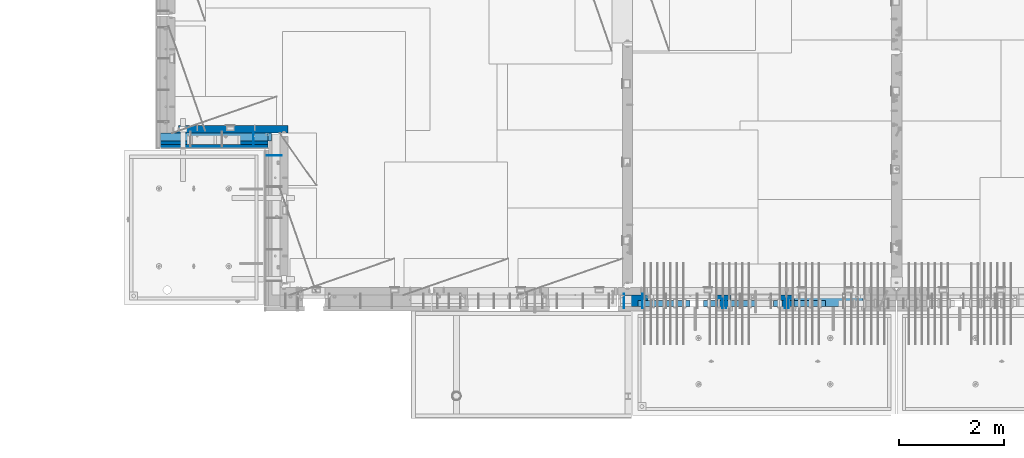
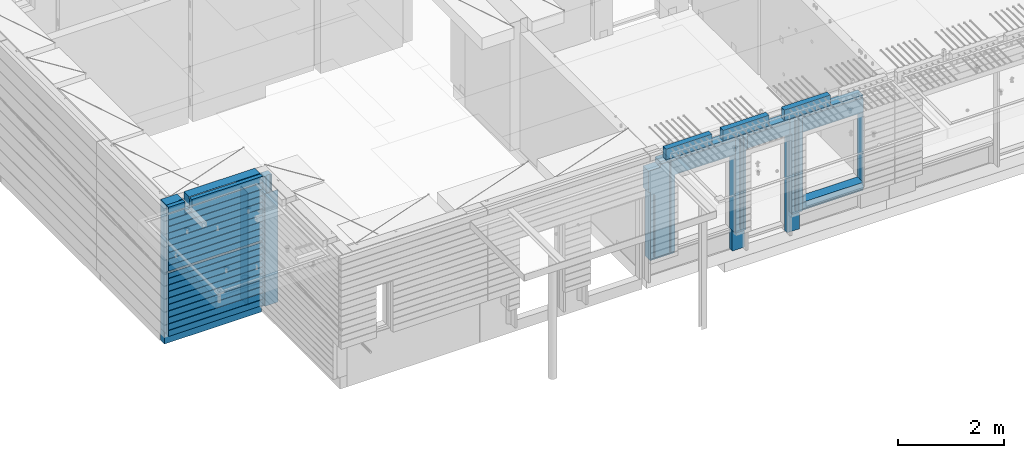
# One storey, part 209 of 325: 20 walls, 7 elements without a shape of their own.
"""IFC2X3 building model written with IfcOpenShell, lengths in millimetres."""

from ifc_helpers import new_model, si_unit, frame, origin_with_axes, place, context, subcontext, project, spatial, faceted_brep, material, type_object, element, aggregate, save


model = new_model("IFC2X3")

# Units and contexts
model_context = context("Model", 3, precision=1e-05, world=origin_with_axes())
body_context = subcontext(model_context, "Body", "Model", "MODEL_VIEW")
ifc_project = project(units=[si_unit("LENGTHUNIT", "METRE", prefix="MILLI"), si_unit("AREAUNIT", "SQUARE_METRE"), si_unit("VOLUMEUNIT", "CUBIC_METRE"), si_unit("MASSUNIT", "GRAM", prefix="KILO"), si_unit("TIMEUNIT", "SECOND"), si_unit("PLANEANGLEUNIT", "RADIAN"), si_unit("SOLIDANGLEUNIT", "STERADIAN"), si_unit("THERMODYNAMICTEMPERATUREUNIT", "DEGREE_CELSIUS"), si_unit("LUMINOUSINTENSITYUNIT", "LUMEN")], contexts=[model_context])

# Site, building, storey
site_placement = place(None, origin_with_axes())
site = spatial("IfcSite", under=ifc_project, at=site_placement, CompositionType="ELEMENT")
building_placement = place(site_placement, origin_with_axes())
building = spatial("IfcBuilding", under=site, at=building_placement, CompositionType="ELEMENT")
storey_placement = place(building_placement, origin_with_axes())
storey = spatial("IfcBuildingStorey", under=building, at=storey_placement, Name="1", CompositionType="ELEMENT", Elevation=0.0)

# Assembly, wall
assembly_1_placement = place(storey_placement, origin_with_axes())
assembly_1 = element("IfcElementAssembly", 1, at=assembly_1_placement, inside=storey, AssemblyPlace="NOTDEFINED", PredefinedType="REINFORCEMENT_UNIT")
ifc_material_1 = material(Name="Undefined")
wall_type_1 = type_object("IfcWallType", PredefinedType="NOTDEFINED")
wall_1_placement = place(assembly_1_placement, frame((10040.0, 10525.0, 83115.0), z_axis=(0.0, 0.0, 1.0), x_axis=(-1.0, 3.00000001838171e-08, 0.0)))
wall_1 = element("IfcWall", 2, at=wall_1_placement, type_object=wall_type_1, material=ifc_material_1, Name="(PD)", context=body_context, shape_type="Brep", body=[
    faceted_brep([(0.0, 5.0, -1300.0), (0.0, 5.0, 1300.0), (280.0, 5.0, 1300.0), (280.0, 5.0, -1300.0), (0.0, -5.0, 1300.0), (280.0, -5.0, 1300.0), (0.0, -5.0, -1300.0), (280.0, -5.0, -1300.0)], [[[0, 1, 2, 3]], [[1, 4, 5, 2]], [[4, 6, 7, 5]], [[6, 0, 3, 7]], [[5, 7, 3, 2]], [[6, 4, 1, 0]]]),
])
aggregate(assembly_1, [wall_1])

assembly_2_placement = place(storey_placement, origin_with_axes())
assembly_2 = element("IfcElementAssembly", 3, at=assembly_2_placement, inside=storey, AssemblyPlace="NOTDEFINED", PredefinedType="REINFORCEMENT_UNIT")
wall_2_placement = place(assembly_2_placement, frame((9500.0, 10980.0, 83115.0), z_axis=(0.0, 0.0, 1.0), x_axis=(0.0, -1.0, 0.0)))
wall_2 = element("IfcWall", 4, at=wall_2_placement, type_object=wall_type_1, material=ifc_material_1, Name="(PD)", context=body_context, shape_type="Brep", body=[
    faceted_brep([(0.0, 5.0, -1300.0), (0.0, 5.0, 1300.0), (280.0, 5.0, 1300.0), (280.0, 5.0, -1300.0), (0.0, -5.0, 1300.0), (280.0, -5.0, 1300.0), (0.0, -5.0, -1300.0), (280.0, -5.0, -1300.0)], [[[0, 1, 2, 3]], [[1, 4, 5, 2]], [[4, 6, 7, 5]], [[6, 0, 3, 7]], [[5, 7, 3, 2]], [[6, 4, 1, 0]]]),
])

# Assemblies, walls
assembly_3_placement = place(storey_placement, origin_with_axes())
assembly_3 = element("IfcElementAssembly", 5, at=assembly_3_placement, inside=storey, AssemblyPlace="NOTDEFINED", PredefinedType="REINFORCEMENT_UNIT")
assembly_4_placement = place(assembly_3_placement, origin_with_axes())
assembly_4 = element("IfcElementAssembly", 6, at=assembly_4_placement, Name="Steel Assembly", AssemblyPlace="NOTDEFINED", PredefinedType="NOTDEFINED")
ifc_material_2 = material()
wall_type_2 = type_object("IfcWallType", PredefinedType="NOTDEFINED")
wall_3_placement = place(assembly_4_placement, frame((16859.9998568133, 7690.00021946163, 84590.0), z_axis=(0.0, 0.0, 1.0), x_axis=(1.0, 0.0, 0.0)))
wall_3 = element("IfcWall", 7, at=wall_3_placement, type_object=wall_type_2, material=ifc_material_2, context=body_context, shape_type="Brep", body=[
    faceted_brep([(0.0, 60.0, -120.0), (0.0, 60.0, 120.0), (1000.0, 60.0, 120.0), (1000.0, 60.0, -120.0), (0.0, -60.0, 120.0), (1000.0, -60.0, 120.0), (0.0, -60.0, -120.0), (1000.0, -60.0, -120.0)], [[[0, 1, 2, 3]], [[1, 4, 5, 2]], [[4, 6, 7, 5]], [[6, 0, 3, 7]], [[5, 7, 3, 2]], [[6, 4, 1, 0]]]),
])
aggregate(assembly_4, [wall_3])
assembly_5_placement = place(assembly_3_placement, origin_with_axes())
assembly_5 = element("IfcElementAssembly", 8, at=assembly_5_placement, Name="Steel Assembly", AssemblyPlace="NOTDEFINED", PredefinedType="NOTDEFINED")
wall_4_placement = place(assembly_5_placement, frame((18109.9998568133, 7690.00021946163, 84590.0), z_axis=(0.0, 0.0, 1.0), x_axis=(1.0, 0.0, 0.0)))
wall_4 = element("IfcWall", 9, at=wall_4_placement, type_object=wall_type_2, material=ifc_material_2, context=body_context, shape_type="Brep", body=[
    faceted_brep([(0.0, 60.0, -120.0), (0.0, 60.0, 120.0), (1000.0, 60.0, 120.0), (1000.0, 60.0, -120.0), (0.0, -60.0, 120.0), (1000.0, -60.0, 120.0), (0.0, -60.0, -120.0), (1000.0, -60.0, -120.0)], [[[0, 1, 2, 3]], [[1, 4, 5, 2]], [[4, 6, 7, 5]], [[6, 0, 3, 7]], [[5, 7, 3, 2]], [[6, 4, 1, 0]]]),
])
aggregate(assembly_5, [wall_4])
assembly_6_placement = place(assembly_3_placement, origin_with_axes())
assembly_6 = element("IfcElementAssembly", 10, at=assembly_6_placement, Name="Steel Assembly", AssemblyPlace="NOTDEFINED", PredefinedType="NOTDEFINED")
aggregate(assembly_3, [assembly_6, assembly_5, assembly_4])
wall_5_placement = place(assembly_6_placement, frame((19449.9998568133, 7690.00021946163, 84590.0), z_axis=(0.0, 0.0, 1.0), x_axis=(1.0, 0.0, 0.0)))
wall_5 = element("IfcWall", 11, at=wall_5_placement, type_object=wall_type_2, material=ifc_material_2, context=body_context, shape_type="Brep", body=[
    faceted_brep([(0.0, 60.0, -120.0), (0.0, 60.0, 120.0), (1000.0, 60.0, 120.0), (1000.0, 60.0, -120.0), (0.0, -60.0, 120.0), (1000.0, -60.0, 120.0), (0.0, -60.0, -120.0), (1000.0, -60.0, -120.0)], [[[0, 1, 2, 3]], [[1, 4, 5, 2]], [[4, 6, 7, 5]], [[6, 0, 3, 7]], [[5, 7, 3, 2]], [[6, 4, 1, 0]]]),
])
aggregate(assembly_6, [wall_5])

# Assembly, wall
assembly_7_placement = place(storey_placement, origin_with_axes())
assembly_7 = element("IfcElementAssembly", 12, at=assembly_7_placement, inside=storey, AssemblyPlace="NOTDEFINED", PredefinedType="REINFORCEMENT_UNIT")
ifc_material_3 = material(Name="COS5gt")
wall_type_3 = type_object("IfcWallType", PredefinedType="NOTDEFINED")
wall_6_placement = place(assembly_7_placement, frame((21175.0, 7740.0, 83247.5), z_axis=(0.0, 0.0, 1.0), x_axis=(-1.0, 3.00000001838171e-08, 0.0)))
wall_6 = element("IfcWall", 13, at=wall_6_placement, type_object=wall_type_3, material=ifc_material_3, context=body_context, shape_type="Brep", body=[
    faceted_brep([(0.00187060721509624, 90.0, 1152.5), (1329.98996185248, 90.0, 1152.5), (1329.98996185248, 110.0, 1152.5), (0.0, 110.0, 1152.5), (0.00187060721509624, 90.0, 1202.5), (1329.98996185248, 90.0, 1202.5), (1599.99312373617, 90.0, 1152.5), (2529.98996185248, 90.0, 1152.5), (2529.98996185248, 110.0, 1152.5), (1599.99312373617, 110.0, 1152.5), (1599.99187060721, 90.0, 1202.5), (2529.98996185248, 90.0, 1202.5), (1600.00051719707, 110.0, 857.5), (1600.00051719707, -10.0, 857.5), (1599.99187060721, -10.0, 1202.5), (2529.98996185248, 110.0, 857.5), (2529.98996185248, -10.0, 1202.5), (2529.98996185248, -10.0, 857.5), (2529.97996185248, -110.0, 1202.5), (2529.97996185248, -110.0, 857.5), (1600.00051719707, -110.0, 857.5), (1599.99996185247, -110.0, 847.5), (1599.99996185247, -10.0, 847.5), (1329.98996185248, -10.0, 1202.5), (1329.98996185248, -10.0, -1007.5), (1329.98996185248, 90.0, -1007.5), (1329.98996185248, 90.0, -957.5), (1329.98996185248, 110.0, -957.5), (1599.99996185247, -10.0, -1007.5), (1599.99996185247, -110.0, -1007.5), (0.0, -110.0, -1007.5), (0.0, 90.0, -1007.5), (0.00187060721509624, 90.0, -957.5), (0.0, 110.0, -957.5), (10.0001357273395, 110.0, -807.5), (40.0001357273395, 110.0, -807.5), (1290.00013572734, 110.0, -807.5), (1320.00013572734, 110.0, -807.5), (1320.00013572734, 110.0, -802.5), (1320.00013572734, 110.0, 807.5), (10.0001357273395, 110.0, 807.5), (10.0001357273395, 110.0, -802.5), (4.05418978139278, -110.000000000001, -813.445945945947), (4.05418978139278, -110.0, 813.445945945947), (1325.94608167329, -110.000000000001, -813.445945945947), (1325.94608167329, -110.0, 813.445945945947), (0.00187060720782029, -110.0, 1202.5), (2799.99187060721, 90.0, 1152.5), (4434.99991748222, 90.0, 1152.5), (4434.99991748222, 109.999999999999, 1152.5), (2799.99187060721, 110.0, 1152.5), (2799.99187060721, 90.0, 1202.5), (4434.99991748221, 90.0, 1202.5), (4415.0, -100.0, 592.503662109375), (4415.0, -110.0, 592.503662109375), (4650.00004873124, -110.0, 592.5), (4650.00004873124, -100.0, 592.503662109375), (4650.00004873124, -110.0, -1007.5), (4650.00004873124, -40.0, -1007.5), (4650.00004873124, -40.0, 592.5), (2804.05342684194, -110.0, 813.445945945947), (2809.99937278789, 110.0, 807.5), (4119.99937278789, 110.0, 807.5), (4125.94531873383, -110.0, 813.445945945947), (4120.53991332843, 90.0, -1007.5), (4125.94531873383, -110.000000000001, -1007.5), (4119.99937278789, 110.0, -957.5), (4120.53991332843, 90.0, -957.5), (4650.00004873124, 90.0, -1007.5), (4650.0, 90.0, -957.5), (4650.00004873124, 110.0, -957.5), (4650.00004873124, 110.0, 592.5), (4700.0, 110.0, 592.5), (4700.00004873124, -40.0, 592.5), (4434.99991748224, 109.999999999998, 1092.50000000006), (4434.99991748224, 49.9999999999982, 1092.50000000006), (4699.99999999997, 49.9999999999982, 1092.50000000006), (4700.0, 110.0, 1092.50000000006), (4434.99991748221, 49.9999999999982, 1202.5), (4434.99991748221, -100.0, 1202.5), (4434.99991748224, -100.0, 1092.50000000006), (4700.0, -100.0, 1092.50000000006), (4699.99999999999, -100.0, 592.503662109375), (4415.0, -100.0, 1202.50000000001), (4415.0, -110.0, 1202.5), (2804.05342684194, -110.000000000001, -1007.5), (2799.9818706072, -110.0, 1202.5), (2799.9818706072, -110.000000000001, -1007.5), (2799.99187060721, 110.0, -957.5), (2809.99937278789, 110.0, -957.5), (2809.45883224735, 90.0, -957.5), (2799.99187060721, 90.0, -957.5), (2809.45883224735, 90.0, -1007.5), (2799.99187060721, 90.0, -1007.5), (2799.99187060721, -10.0, -1007.5), (2799.99187060721, -10.0, 1202.5)], [[[0, 1, 2, 3]], [[4, 5, 1, 0]], [[6, 7, 8, 9]], [[10, 11, 7, 6]], [[9, 12, 13, 14, 10, 6]], [[15, 12, 9, 8]], [[16, 17, 15, 8, 7, 11]], [[18, 19, 17, 16]], [[20, 13, 12, 15, 17, 19]], [[20, 21, 22, 13]], [[23, 24, 25, 26, 27, 2, 1, 5]], [[14, 13, 22, 28, 24, 23]], [[21, 29, 28, 22]], [[24, 28, 29, 30, 31, 25]], [[32, 26, 25, 31]], [[33, 27, 26, 32]], [[27, 33, 3, 2], [34, 35, 36, 37, 38, 39, 40, 41]], [[42, 34, 41, 40, 43]], [[44, 37, 36, 35, 34, 42]], [[38, 37, 44, 45, 39]], [[43, 40, 39, 45]], [[46, 30, 29, 21, 20, 19, 18], [44, 42, 43, 45]], [[3, 33, 32, 31, 30, 46, 4, 0]], [[46, 18, 16, 11, 10, 14, 23, 5, 4]], [[47, 48, 49, 50]], [[51, 52, 48, 47]], [[53, 54, 55, 56]], [[55, 57, 58, 59, 56]], [[60, 61, 62, 63]], [[64, 65, 63, 62, 66, 67]], [[58, 57, 65, 64, 68]], [[67, 69, 68, 64]], [[66, 70, 69, 67]], [[71, 59, 58, 68, 69, 70]], [[71, 72, 73, 59]], [[74, 75, 76, 77]], [[75, 78, 79, 80]], [[76, 75, 80, 81]], [[72, 77, 76, 81, 82, 73]], [[56, 59, 73, 82]], [[81, 80, 79, 83, 53, 56, 82]], [[84, 54, 53, 83]], [[85, 60, 63, 65, 57, 55, 54, 84, 86, 87]], [[88, 89, 90, 91]], [[61, 60, 85, 92, 90, 89]], [[91, 90, 92, 93]], [[85, 87, 94, 93, 92]], [[86, 95, 94, 87]], [[50, 88, 91, 93, 94, 95, 51, 47]], [[74, 77, 72, 71, 70, 66, 62, 61, 89, 88, 50, 49]], [[78, 75, 74, 49, 48, 52]], [[95, 86, 84, 83, 79, 78, 52, 51]]]),
])

# Wall
wall_7_placement = place(assembly_2_placement, frame((10160.0, 10840.0, 83247.5), z_axis=(0.0, 0.0, 1.0), x_axis=(-1.0, 3.00000001838171e-08, 0.0)))
wall_7 = element("IfcWall", 14, at=wall_7_placement, type_object=wall_type_3, material=ifc_material_3, context=body_context, shape_type="Brep", body=[
    faceted_brep([(2075.0, -110.0, 1492.5), (2075.0, 90.0, 1492.5), (2075.0, 90.0, 1442.5), (2075.0, 110.0, 1442.5), (2075.0, 109.999999999996, 1222.5), (2075.0, -110.000000000004, 1222.5), (1925.0, 110.0, 1222.5), (1925.0, -110.0, 1222.5), (1925.0, -110.0, 1492.5), (1925.0, 110.0, 1442.5), (1925.0, 90.0, 1442.5), (1925.0, 90.0, 1492.5), (2161.0, 110.0, 1492.5), (2161.0, 110.0, 1442.5), (2161.0, 90.0, 1442.5), (2161.0, 90.0, 1492.5), (375.0, 110.0, -1442.5), (2435.0002741176, 110.0, -1442.5), (2435.0002741176, 90.0, -1442.5), (375.0, 90.0, -1442.5), (2435.0002741176, 110.0, 1492.5), (2435.0002741176, -110.0, 1492.5), (2435.0002741176, -110.0, -1492.5), (2435.0002741176, 90.0, -1492.5), (375.0, -110.0, -1492.5), (375.0, 90.0, -1492.5), (375.0, -110.0, 1492.5), (375.0, 90.0, 1492.5), (375.0, 90.0, 1442.5), (375.0, 110.0, 1442.5)], [[[0, 1, 2, 3, 4, 5]], [[5, 4, 6, 7]], [[8, 7, 6, 9, 10, 11]], [[12, 13, 14, 15]], [[16, 17, 18, 19]], [[20, 21, 22, 23, 18, 17]], [[22, 24, 25, 23]], [[19, 18, 23, 25]], [[24, 26, 27, 28, 29, 16, 19, 25]], [[27, 26, 8, 11]], [[28, 27, 11, 10]], [[29, 28, 10, 9]], [[4, 3, 13, 12, 20, 17, 16, 29, 9, 6]], [[14, 13, 3, 2]], [[15, 14, 2, 1]], [[21, 20, 12, 15, 1, 0]], [[26, 24, 22, 21, 0, 5, 7, 8]]]),
])

ifc_material_4 = material(Name="CONCRETE/C30/37")
wall_type_4 = type_object("IfcWallType", PredefinedType="NOTDEFINED")
wall_8_placement = place(assembly_2_placement, frame((10160.0, 10687.5, 83247.5), z_axis=(0.0, 0.0, 1.0), x_axis=(-1.0, 3.00000001838171e-08, 0.0)))
wall_8 = element("IfcWall", 15, at=wall_8_placement, type_object=wall_type_4, material=ifc_material_4, context=body_context, shape_type="Brep", body=[
    faceted_brep([(374.995117187496, 12.4998847984862, -32.6842138223001), (2434.99994039505, 12.4998847984862, -32.6842016856972), (2434.99994039504, 42.5, -32.6842016856972), (375.0, 42.5, -32.6842138223001), (374.995117187496, 12.4998847984862, 17.3157872826123), (2434.99994039505, 12.4998847984862, 17.3157872826123), (375.0, 42.5, 17.3157872826123), (2434.99994039504, 42.5, 17.3157872826123), (2434.99994039504, -42.5, 1492.5), (2434.99994039504, 42.5, 1492.5), (2075.0, 42.5, 1492.5), (2075.0, -42.5, 1492.5), (2434.99994039504, 42.5, 1356.99999988925), (2075.0, 42.4999994127757, 1356.99999988925), (2434.99994039505, 32.4999991126988, 1355.00000040044), (2075.0, 32.4999991126933, 1355.00000040043), (2434.99994039505, 32.4999992506928, 1344.99999999921), (2075.0, 32.4999992506928, 1344.9999999992), (2075.0, -42.5000000000036, 1222.5), (2075.0, 42.4999994593163, 1222.5), (1925.0, 42.5, 1222.5), (1925.0, -42.5, 1222.5), (2075.0, 42.4999996925035, 1342.99999994476), (2434.99994039504, 42.5, 1342.99999994476), (375.0, 32.4999992506928, 144.999999999214), (2434.99994039504, 32.4999992506928, 144.999999999214), (2434.99994039504, 42.5, 142.999999944761), (375.0, 42.5, 142.999999944761), (375.0, 32.4999991126988, 155.00000040044), (2434.99994039504, 32.4999991126988, 155.00000040044), (375.0, 42.5, 156.999999889245), (2434.99994039504, 42.5, 156.999999889245), (375.0, 42.5, 292.999999944761), (2434.99994039504, 42.5, 292.999999944761), (375.000000000002, 32.4999992506928, 294.999999999214), (2434.99994039504, 32.4999992506928, 294.999999999214), (375.000000000002, 32.4999991126988, 305.00000040044), (2434.99994039504, 32.4999991126988, 305.00000040044), (375.0, 42.5, 306.999999889245), (2434.99994039504, 42.5, 306.999999889245), (375.0, 42.5, 442.999999944761), (2434.99994039504, 42.5, 442.999999944761), (375.0, 32.4999992506928, 444.999999999214), (2434.99994039504, 32.4999992506928, 444.999999999214), (375.0, 32.4999991126988, 455.00000040044), (2434.99994039504, 32.4999991126988, 455.00000040044), (375.0, 42.5, 456.999999889245), (2434.99994039504, 42.5, 456.999999889245), (375.0, 42.5, 592.999999944761), (2434.99994039504, 42.5, 592.999999944761), (375.0, 32.4999992506928, 594.999999999214), (2434.99994039505, 32.4999992506928, 594.999999999214), (375.0, 32.4999991126988, 605.00000040044), (2434.99994039505, 32.4999991126988, 605.00000040044), (375.0, 42.5, 606.999999889245), (2434.99994039504, 42.5, 606.999999889245), (375.0, 42.5, 742.999999944761), (2434.99994039504, 42.5, 742.999999944761), (375.0, 32.4999992506928, 744.999999999214), (2434.99994039505, 32.4999992506928, 744.999999999214), (375.0, 32.4999991126988, 755.00000040044), (2434.99994039505, 32.4999991126988, 755.00000040044), (375.0, 42.5, 756.999999889245), (2434.99994039504, 42.5, 756.999999889245), (375.0, 42.5, 892.999999944761), (2434.99994039504, 42.5, 892.999999944761), (374.999999999998, 32.4999992506928, 894.999999999214), (2434.99994039505, 32.4999992506928, 894.999999999214), (374.999999999998, 32.4999991126988, 905.00000040044), (2434.99994039505, 32.4999991126988, 905.00000040044), (375.0, 42.5, 906.999999889245), (2434.99994039504, 42.5, 906.999999889245), (375.0, 42.5, 1042.99999994476), (2434.99994039504, 42.5, 1042.99999994476), (375.0, 32.4999992506928, 1044.99999999921), (2434.99994039505, 32.4999992506928, 1044.99999999921), (375.0, 32.4999991126988, 1055.00000040044), (2434.99994039505, 32.4999991126988, 1055.00000040044), (375.0, 42.5, 1056.99999988925), (2434.99994039504, 42.5, 1056.99999988925), (375.0, 42.5, 1192.99999994476), (2434.99994039504, 42.5, 1192.99999994476), (375.0, 32.4999992506928, 1194.99999999921), (2434.99994039505, 32.4999992506928, 1194.99999999921), (375.0, 32.4999991126988, 1205.00000040044), (2434.99994039505, 32.4999991126988, 1205.00000040044), (375.0, 42.5, 1206.99999988925), (2434.99994039504, 42.5, 1206.99999988925), (375.0, 42.5, 1342.99999994476), (1925.0, 42.5, 1342.99999994476), (375.0, 32.4999992506928, 1344.99999999921), (1925.0, 32.4999992506928, 1344.99999999921), (375.0, 32.4999991126988, 1355.00000040044), (1925.0, 32.4999991126988, 1355.00000040044), (375.0, 42.5, 1356.99999988925), (1925.0, 42.5, 1356.99999988925), (375.0, 42.5, 1492.5), (375.0, -42.5, 1492.5), (1925.0, -42.5, 1492.5), (1925.0, 42.5, 1492.5), (375.0, -42.5, -1492.5), (2434.99994039504, -42.5, -1492.5), (375.0, 42.5, -1492.5), (2434.99994039504, 42.5, -1492.5), (375.0, 42.5, -1357.00000005524), (2434.99994039504, 42.5, -1357.00000005524), (375.0, 32.4999992506928, -1355.00000000079), (2434.99994039504, 32.4999992506928, -1355.00000000079), (375.0, 32.4999991126988, -1344.99999959956), (2434.99994039504, 32.4999991126988, -1344.99999959956), (375.0, 42.5, -1343.00000011075), (2434.99994039504, 42.5, -1343.00000011075), (375.0, 42.5, -1207.00000005524), (2434.99994039504, 42.5, -1207.00000005524), (375.0, 32.4999992506928, -1205.0000000008), (2434.99994039504, 32.4999992506928, -1205.0000000008), (375.0, 32.4999991126915, -1194.99999959957), (2434.99994039504, 32.4999991126915, -1194.99999959957), (375.0, 42.5, -1193.00000011075), (2434.99994039504, 42.5, -1193.00000011075), (375.0, 42.5, -1057.00000005524), (2434.99994039504, 42.5, -1057.00000005524), (375.0, 32.4999992506928, -1055.00000000079), (2434.99994039504, 32.4999992506928, -1055.00000000079), (375.0, 32.4999991126988, -1044.99999959956), (2434.99994039504, 32.4999991126988, -1044.99999959956), (375.0, 42.5, -1043.00000011075), (2434.99994039504, 42.5, -1043.00000011075), (375.0, 42.5, -907.000000055239), (2434.99994039504, 42.5, -907.000000055239), (375.0, 32.4999992506928, -905.000000000786), (2434.99994039504, 32.4999992506928, -905.000000000786), (375.0, 32.4999991126988, -894.99999959956), (2434.99994039504, 32.4999991126988, -894.99999959956), (375.0, 42.5, -893.000000110755), (2434.99994039504, 42.5, -893.000000110755), (375.0, 42.5, -757.000000055239), (2434.99994039504, 42.5, -757.000000055239), (375.0, 32.4999992506928, -755.000000000786), (2434.99994039504, 32.4999992506928, -755.000000000786), (375.0, 32.4999991126988, -744.99999959956), (2434.99994039504, 32.4999991126988, -744.99999959956), (375.0, 42.5, -743.000000110755), (2434.99994039504, 42.5, -743.000000110755), (375.0, 42.5, -607.000000055239), (2434.99994039504, 42.5, -607.000000055239), (375.0, 32.4999992506928, -605.000000000786), (2434.99994039504, 32.4999992506928, -605.000000000786), (375.0, 32.4999991126988, -594.99999959956), (2434.99994039504, 32.4999991126988, -594.99999959956), (375.0, 42.5, -593.000000110755), (2434.99994039504, 42.5, -593.000000110755), (375.0, 42.5, -457.000000055239), (2434.99994039504, 42.5, -457.000000055239), (375.0, 32.4999992506928, -455.000000000786), (2434.99994039504, 32.4999992506928, -455.000000000786), (375.0, 32.4999991126988, -444.99999959956), (2434.99994039504, 32.4999991126988, -444.99999959956), (375.0, 42.5, -443.000000110755), (2434.99994039504, 42.5, -443.000000110755), (375.0, 42.5, -307.000000055239), (2434.99994039504, 42.5, -307.000000055239), (375.0, 32.4999992506928, -305.000000000786), (2434.99994039504, 32.4999992506928, -305.000000000786), (375.0, 32.4999991126988, -294.99999959956), (2434.99994039504, 32.4999991126988, -294.99999959956), (375.0, 42.5, -293.000000110755), (2434.99994039504, 42.5, -293.000000110755), (375.0, 42.5, -157.000000055239), (2434.99994039504, 42.5, -157.000000055239), (375.0, 32.4999992506928, -155.000000000786), (2434.99994039504, 32.4999992506928, -155.000000000786), (375.0, 32.4999991126988, -144.99999959956), (2434.99994039504, 32.4999991126988, -144.99999959956), (375.0, 42.5, -143.000000110755), (2434.99994039504, 42.5, -143.000000110755)], [[[0, 1, 2, 3]], [[4, 5, 1, 0]], [[6, 7, 5, 4]], [[8, 9, 10, 11]], [[9, 12, 13, 10]], [[12, 14, 15, 13]], [[14, 16, 17, 15]], [[18, 19, 20, 21]], [[11, 10, 13, 15, 17, 22, 19, 18]], [[16, 23, 22, 17]], [[24, 25, 26, 27]], [[28, 29, 25, 24]], [[30, 31, 29, 28]], [[31, 30, 32, 33]], [[34, 35, 33, 32]], [[36, 37, 35, 34]], [[38, 39, 37, 36]], [[39, 38, 40, 41]], [[42, 43, 41, 40]], [[44, 45, 43, 42]], [[46, 47, 45, 44]], [[47, 46, 48, 49]], [[50, 51, 49, 48]], [[52, 53, 51, 50]], [[54, 55, 53, 52]], [[55, 54, 56, 57]], [[58, 59, 57, 56]], [[60, 61, 59, 58]], [[62, 63, 61, 60]], [[63, 62, 64, 65]], [[66, 67, 65, 64]], [[68, 69, 67, 66]], [[70, 71, 69, 68]], [[71, 70, 72, 73]], [[74, 75, 73, 72]], [[76, 77, 75, 74]], [[78, 79, 77, 76]], [[79, 78, 80, 81]], [[82, 83, 81, 80]], [[84, 85, 83, 82]], [[86, 87, 85, 84]], [[19, 22, 23, 87, 86, 88, 89, 20]], [[88, 90, 91, 89]], [[90, 92, 93, 91]], [[92, 94, 95, 93]], [[96, 97, 98, 99]], [[94, 96, 99, 95]], [[98, 21, 20, 89, 91, 93, 95, 99]], [[97, 100, 101, 8, 11, 18, 21, 98]], [[100, 102, 103, 101]], [[103, 102, 104, 105]], [[106, 107, 105, 104]], [[108, 109, 107, 106]], [[110, 111, 109, 108]], [[111, 110, 112, 113]], [[114, 115, 113, 112]], [[116, 117, 115, 114]], [[118, 119, 117, 116]], [[119, 118, 120, 121]], [[122, 123, 121, 120]], [[124, 125, 123, 122]], [[126, 127, 125, 124]], [[127, 126, 128, 129]], [[130, 131, 129, 128]], [[132, 133, 131, 130]], [[134, 135, 133, 132]], [[135, 134, 136, 137]], [[138, 139, 137, 136]], [[140, 141, 139, 138]], [[142, 143, 141, 140]], [[143, 142, 144, 145]], [[146, 147, 145, 144]], [[148, 149, 147, 146]], [[150, 151, 149, 148]], [[151, 150, 152, 153]], [[154, 155, 153, 152]], [[156, 157, 155, 154]], [[158, 159, 157, 156]], [[159, 158, 160, 161]], [[162, 163, 161, 160]], [[164, 165, 163, 162]], [[166, 167, 165, 164]], [[167, 166, 168, 169]], [[170, 171, 169, 168]], [[172, 173, 171, 170]], [[174, 175, 173, 172]], [[175, 174, 3, 2]], [[26, 25, 29, 31, 33, 35, 37, 39, 41, 43, 45, 47, 49, 51, 53, 55, 57, 59, 61, 63, 65, 67, 69, 71, 73, 75, 77, 79, 81, 83, 85, 87, 23, 16, 14, 12, 9, 8, 101, 103, 105, 107, 109, 111, 113, 115, 117, 119, 121, 123, 125, 127, 129, 131, 133, 135, 137, 139, 141, 143, 145, 147, 149, 151, 153, 155, 157, 159, 161, 163, 165, 167, 169, 171, 173, 175, 2, 1, 5, 7]], [[27, 26, 7, 6]], [[3, 174, 172, 170, 168, 166, 164, 162, 160, 158, 156, 154, 152, 150, 148, 146, 144, 142, 140, 138, 136, 134, 132, 130, 128, 126, 124, 122, 120, 118, 116, 114, 112, 110, 108, 106, 104, 102, 100, 97, 96, 94, 92, 90, 88, 86, 84, 82, 80, 78, 76, 74, 72, 70, 68, 66, 64, 62, 60, 58, 56, 54, 52, 50, 48, 46, 44, 42, 40, 38, 36, 34, 32, 30, 28, 24, 27, 6, 4, 0]]]),
])

ifc_material_5 = material(Name="CONCRETE/C25/30")
wall_type_5 = type_object("IfcWallType", PredefinedType="NOTDEFINED")
wall_9_placement = place(assembly_2_placement, frame((10160.0, 11025.0, 82977.5), z_axis=(0.0, 0.0, 1.0), x_axis=(-1.0, 3.00000001838171e-08, 0.0)))
wall_9 = element("IfcWall", 16, at=wall_9_placement, type_object=wall_type_5, material=ifc_material_5, context=body_context, shape_type="Brep", body=[
    faceted_brep([(2095.0, 32.0, 1492.5), (2095.0, 32.0, -1492.5), (2145.0, 44.9999999999982, -1492.5), (2145.0, 44.9999999999982, 1492.5), (2095.0, -75.0, 1492.5), (2095.0, -75.0, -1492.5), (24.999999998452, 75.0000022791301, 1231.4999999969), (25.0000034119694, 75.0, 1492.5), (35.0000012841592, 54.9999974671882, 1492.5), (34.999999998452, 55.0000022791301, 1231.4999999969), (34.999999998452, 55.0000022791301, -1223.5000000031), (24.999999998452, 75.0000022791301, -1223.5000000031), (115.000000752763, 54.9999994575555, 1492.5), (114.999999998452, 55.0000022791301, 1231.4999999969), (114.999999998452, 55.0000022791301, -1223.5000000031), (124.999999335741, 75.0, 1492.5), (124.999999998452, 75.0000002190172, 1231.4999999969), (124.999999998452, 75.0000022791301, -1223.5000000031), (2145.0, 75.0, 1492.5), (2145.0, 75.0, -1492.5), (124.999999335741, 75.0, -1492.5), (115.000000752763, 54.9999994575555, -1492.5), (35.0000012841592, 54.9999974671882, -1492.5), (25.0000034119694, 75.0, -1492.5), (0.0, 75.0, -1492.5), (0.0, 75.0, 1492.5), (0.0, -75.0, -1492.5), (0.0, -75.0, 1492.5)], [[[0, 1, 2, 3]], [[4, 5, 1, 0]], [[6, 7, 8, 9, 10, 11]], [[12, 13, 14, 10, 9, 8]], [[15, 16, 17, 14, 13, 12]], [[16, 15, 18, 19, 20, 17]], [[17, 20, 21, 14]], [[14, 21, 22, 10]], [[11, 10, 22, 23]], [[24, 25, 7, 6, 11, 23]], [[26, 27, 25, 24]], [[3, 18, 15, 12, 8, 7, 25, 27, 4, 0]], [[19, 18, 3, 2]], [[26, 24, 23, 22, 21, 20, 19, 2, 1, 5]], [[27, 26, 5, 4]]]),
])

ifc_material_6 = material(Name="SPU")
wall_type_6 = type_object("IfcWallType", PredefinedType="NOTDEFINED")
wall_10_placement = place(assembly_2_placement, frame((9845.0, 10875.0, 81620.0), z_axis=(0.0, 0.0, 1.0), x_axis=(-1.0, 3.00000001838171e-08, 0.0)))
wall_10 = element("IfcWall", 17, at=wall_10_placement, type_object=wall_type_6, material=ifc_material_6, context=body_context, shape_type="Brep", body=[
    faceted_brep([(60.0, -75.0, 135.0), (60.0, 75.0, 135.0), (60.0, 75.0, 120.0), (60.0, -75.0, 120.0), (0.0, -75.0, 120.0), (0.0, 75.0, 120.0), (2119.99999772087, -75.0, 135.0), (2119.99999772087, -75.0, -135.0), (2119.99999772087, 75.0, -135.0), (2119.99999772087, 75.0, 135.0), (0.0, -75.0, -135.0), (0.0, 75.0, -135.0)], [[[0, 1, 2, 3]], [[4, 3, 2, 5]], [[6, 7, 8, 9]], [[10, 11, 8, 7]], [[11, 10, 4, 5]], [[1, 9, 8, 11, 5, 2]], [[6, 9, 1, 0]], [[10, 7, 6, 0, 3, 4]]]),
])

aggregate(assembly_2, [wall_10, wall_2, wall_8, wall_7, wall_9])

wall_type_7 = type_object("IfcWallType", PredefinedType="NOTDEFINED")
wall_11_placement = place(assembly_7_placement, frame((18475.0, 7780.0, 83365.0), z_axis=(0.0, 0.0, 1.0), x_axis=(0.0, -1.0, 0.0)))
wall_11 = element("IfcWall", 18, at=wall_11_placement, type_object=wall_type_7, material=ifc_material_1, Name="(PD)", context=body_context, shape_type="Brep", body=[
    faceted_brep([(0.0, 5.0, -1050.0), (0.0, 5.0, 1050.0), (180.0, 5.0, 1050.0), (180.0, 5.0, -1050.0), (0.0, -5.0, 1050.0), (180.0, -5.0, 1050.0), (0.0, -5.0, -1050.0), (180.0, -5.0, -1050.0)], [[[0, 1, 2, 3]], [[1, 4, 5, 2]], [[4, 6, 7, 5]], [[6, 0, 3, 7]], [[5, 7, 3, 2]], [[6, 4, 1, 0]]]),
])

wall_12_placement = place(assembly_7_placement, frame((18545.0, 7780.0, 83365.0), z_axis=(0.0, 0.0, 1.0), x_axis=(0.0, -1.0, 0.0)))
wall_12 = element("IfcWall", 19, at=wall_12_placement, type_object=wall_type_7, material=ifc_material_1, Name="(PD)", context=body_context, shape_type="Brep", body=[
    faceted_brep([(0.0, 5.0, -1050.0), (0.0, 5.0, 1050.0), (180.0, 5.0, 1050.0), (180.0, 5.0, -1050.0), (0.0, -5.0, 1050.0), (180.0, -5.0, 1050.0), (0.0, -5.0, -1050.0), (180.0, -5.0, -1050.0)], [[[0, 1, 2, 3]], [[1, 4, 5, 2]], [[4, 6, 7, 5]], [[6, 0, 3, 7]], [[5, 7, 3, 2]], [[6, 4, 1, 0]]]),
])

wall_13_placement = place(assembly_7_placement, frame((16945.0, 7880.0, 83365.0), z_axis=(0.0, 0.0, 1.0), x_axis=(0.0, -1.0, 0.0)))
wall_13 = element("IfcWall", 20, at=wall_13_placement, type_object=wall_type_7, material=ifc_material_1, Name="(PD)", context=body_context, shape_type="Brep", body=[
    faceted_brep([(0.0, 5.0, -1050.0), (0.0, 5.0, 1050.0), (280.0, 5.0, 1050.0), (280.0, 5.0, -1050.0), (0.0, -5.0, 1050.0), (280.0, -5.0, 1050.0), (0.0, -5.0, -1050.0), (280.0, -5.0, -1050.0)], [[[0, 1, 2, 3]], [[1, 4, 5, 2]], [[4, 6, 7, 5]], [[6, 0, 3, 7]], [[5, 7, 3, 2]], [[6, 4, 1, 0]]]),
])

wall_14_placement = place(assembly_7_placement, frame((19675.0, 7779.99999999997, 83365.0), z_axis=(0.0, 0.0, 1.0), x_axis=(0.0, -1.0, 0.0)))
wall_14 = element("IfcWall", 21, at=wall_14_placement, type_object=wall_type_7, material=ifc_material_1, Name="(PD)", context=body_context, shape_type="Brep", body=[
    faceted_brep([(0.0, 5.0, -1050.0), (0.0, 5.0, 1050.0), (180.0, 5.0, 1050.0), (180.0, 5.0, -1050.0), (0.0, -5.0, 1050.0), (180.0, -5.0, 1050.0), (0.0, -5.0, -1050.0), (180.0, -5.0, -1050.0)], [[[0, 1, 2, 3]], [[1, 4, 5, 2]], [[4, 6, 7, 5]], [[6, 0, 3, 7]], [[5, 7, 3, 2]], [[6, 4, 1, 0]]]),
])

wall_15_placement = place(assembly_7_placement, frame((19745.0, 7780.0, 83365.0), z_axis=(0.0, 0.0, 1.0), x_axis=(0.0, -1.0, 0.0)))
wall_15 = element("IfcWall", 22, at=wall_15_placement, type_object=wall_type_7, material=ifc_material_1, Name="(PD)", context=body_context, shape_type="Brep", body=[
    faceted_brep([(0.0, 5.0, -1050.0), (0.0, 5.0, 1050.0), (180.0, 5.0, 1050.0), (180.0, 5.0, -1050.0), (0.0, -5.0, 1050.0), (180.0, -5.0, 1050.0), (0.0, -5.0, -1050.0), (180.0, -5.0, -1050.0)], [[[0, 1, 2, 3]], [[1, 4, 5, 2]], [[4, 6, 7, 5]], [[6, 0, 3, 7]], [[5, 7, 3, 2]], [[6, 4, 1, 0]]]),
])

ifc_material_7 = material(Name="CONCRETE/C35/45")
wall_type_8 = type_object("IfcWallType", PredefinedType="NOTDEFINED")
wall_16_placement = place(assembly_7_placement, frame((18645.0200381475, 7800.0, 83112.5), z_axis=(0.0, 0.0, 1.0), x_axis=(-1.0, 3.00000001838171e-08, 0.0)))
wall_16 = element("IfcWall", 23, at=wall_16_placement, type_object=wall_type_8, material=ifc_material_7, context=body_context, shape_type="Brep", body=[
    faceted_brep([(0.0, 50.0, -1357.5), (0.0, 50.0, 1357.5), (270.001908754726, 50.0, 1357.5), (270.001908754726, 50.0, -1357.5), (0.0, -50.0, 1357.5), (270.001908754726, -50.0, 1357.5), (0.0, -50.0, -1357.5), (270.001908754726, -50.0, -1357.5)], [[[0, 1, 2, 3]], [[1, 4, 5, 2]], [[4, 6, 7, 5]], [[6, 0, 3, 7]], [[5, 7, 3, 2]], [[6, 4, 1, 0]]]),
])

wall_17_placement = place(assembly_7_placement, frame((19845.0100381475, 7800.0, 83112.5), z_axis=(0.0, 0.0, 1.0), x_axis=(-1.0, 3.00000001838171e-08, 0.0)))
wall_17 = element("IfcWall", 24, at=wall_17_placement, type_object=wall_type_8, material=ifc_material_7, context=body_context, shape_type="Brep", body=[
    faceted_brep([(0.0, 50.0, -1357.5), (0.0, 50.0, 1357.5), (270.001908754726, 50.0, 1357.5), (270.001908754726, 50.0, -1357.5), (0.0, -50.0, 1357.5), (270.001908754726, -50.0, 1357.5), (0.0, -50.0, -1357.5), (270.001908754726, -50.0, -1357.5)], [[[0, 1, 2, 3]], [[1, 4, 5, 2]], [[4, 6, 7, 5]], [[6, 0, 3, 7]], [[5, 7, 3, 2]], [[6, 4, 1, 0]]]),
])

wall_type_9 = type_object("IfcWallType", PredefinedType="NOTDEFINED")
wall_18_placement = place(assembly_7_placement, frame((18645.0100381475, 7690.0, 83102.5), z_axis=(0.0, 0.0, 1.0), x_axis=(-1.0, 3.00000001838171e-08, 0.0)))
wall_18 = element("IfcWall", 25, at=wall_18_placement, type_object=wall_type_9, material=ifc_material_6, context=body_context, shape_type="Brep", body=[
    faceted_brep([(40.0101738748635, -60.0, 1002.5), (40.0101738748635, 60.0, 1002.5), (40.0101738748635, 60.0, -862.5), (40.0101738748635, -60.0, -862.5), (0.0, -60.0, 962.489826125151), (0.0, 60.0, 962.489826125151), (270.001908754726, 60.0, 1347.5), (270.001908754726, -60.0, 1347.5), (270.001908754726, -60.0, -862.5), (270.001908754726, 60.0, -862.5), (0.0, 60.0, 1347.5), (0.0, -60.0, 1347.5)], [[[0, 1, 2, 3]], [[4, 5, 1, 0]], [[6, 7, 8, 9]], [[10, 11, 7, 6]], [[3, 8, 7, 11, 4, 0]], [[9, 8, 3, 2]], [[10, 6, 9, 2, 1, 5]], [[11, 10, 5, 4]]]),
])

wall_19_placement = place(assembly_7_placement, frame((19845.0100381475, 7690.0, 83102.5), z_axis=(0.0, 0.0, 1.0), x_axis=(-1.0, 3.00000001838171e-08, 0.0)))
wall_19 = element("IfcWall", 26, at=wall_19_placement, type_object=wall_type_9, material=ifc_material_6, context=body_context, shape_type="Brep", body=[
    faceted_brep([(230.01055534459, -60.0, 1002.5), (230.01055534459, 60.0, 1002.5), (270.001908754726, 60.0, 1002.5), (270.001908754726, -60.0, 1002.5), (230.01055534459, -60.0, -862.5), (230.01055534459, 60.0, -862.5), (0.0, -60.0, 1347.5), (0.0, 60.0, 1347.5), (0.0, 60.0, -862.5), (0.0, -60.0, -862.5), (270.001908754726, -60.0, 1347.5), (270.001908754726, 60.0, 1347.5)], [[[0, 1, 2, 3]], [[4, 5, 1, 0]], [[6, 7, 8, 9]], [[7, 6, 10, 11]], [[11, 10, 3, 2]], [[8, 7, 11, 2, 1, 5]], [[9, 8, 5, 4]], [[10, 6, 9, 4, 0, 3]]]),
])

wall_type_10 = type_object("IfcWallType", PredefinedType="NOTDEFINED")
wall_20_placement = place(assembly_7_placement, frame((16595.0, 7880.0, 83040.0), z_axis=(0.0, 0.0, 1.0), x_axis=(0.0, -1.0, 0.0)))
wall_20 = element("IfcWall", 27, at=wall_20_placement, type_object=wall_type_10, material=ifc_material_1, Name="(PD)", context=body_context, shape_type="Brep", body=[
    faceted_brep([(0.0, 5.0, -725.0), (0.0, 5.0, 725.0), (280.0, 5.0, 725.0), (280.0, 5.0, -725.0), (0.0, -5.0, 725.0), (280.0, -5.0, 725.0), (0.0, -5.0, -725.0), (280.0, -5.0, -725.0)], [[[0, 1, 2, 3]], [[1, 4, 5, 2]], [[4, 6, 7, 5]], [[6, 0, 3, 7]], [[5, 7, 3, 2]], [[6, 4, 1, 0]]]),
])

aggregate(assembly_7, [wall_16, wall_18, wall_19, wall_20, wall_11, wall_12, wall_17, wall_13, wall_14, wall_15, wall_6])

save(model, "model.ifc")
